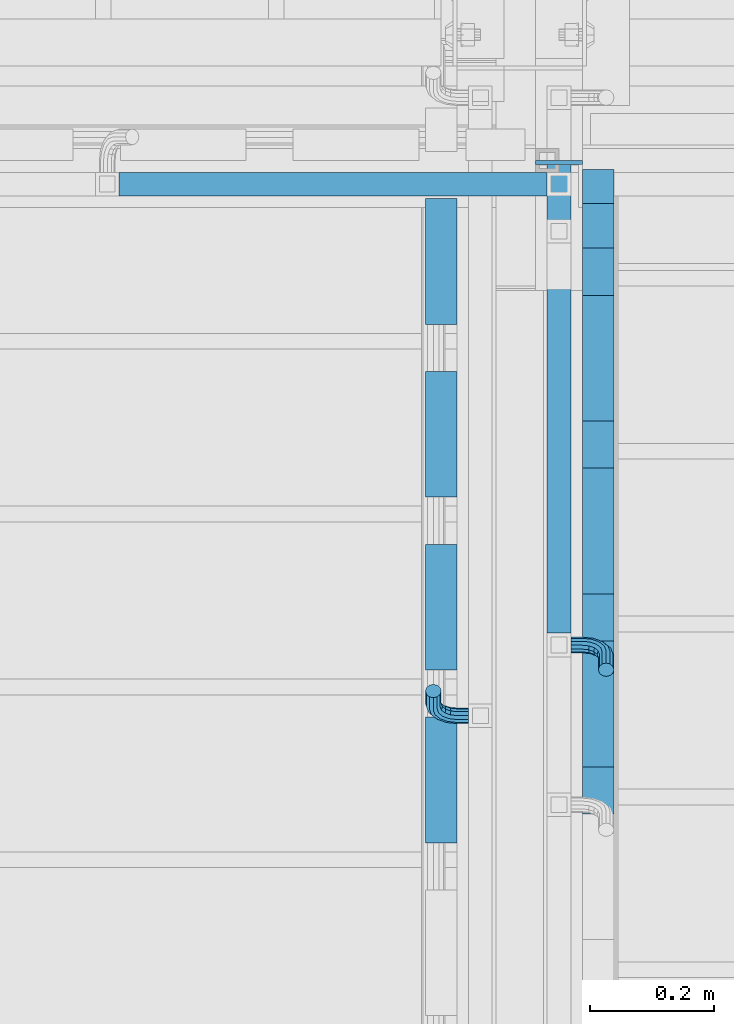
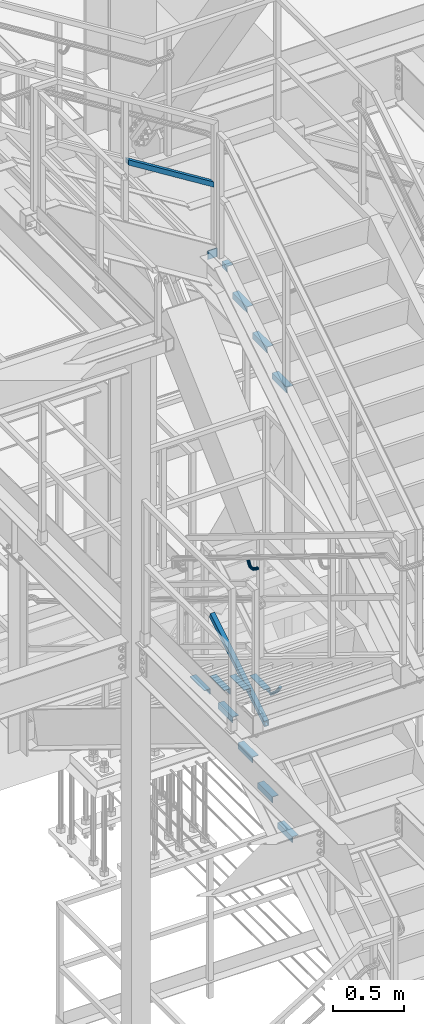
# One storey, part 2087 of 3843: 15 beams, 2 members, 6 elements without a shape of their own.
"""IFC2X3 building model written with IfcOpenShell, lengths in millimetres."""

from ifc_helpers import new_model, si_unit, frame, origin_with_axes, place, context, subcontext, project, spatial, faceted_brep, material, type_object, element, aggregate, save


model = new_model("IFC2X3")

# Units and contexts
model_context = context("Model", 3, precision=1e-05, world=origin_with_axes())
body_context = subcontext(model_context, "Body", "Model", "MODEL_VIEW")
ifc_project = project(units=[si_unit("LENGTHUNIT", "METRE", prefix="MILLI"), si_unit("AREAUNIT", "SQUARE_METRE"), si_unit("VOLUMEUNIT", "CUBIC_METRE"), si_unit("MASSUNIT", "GRAM", prefix="KILO"), si_unit("TIMEUNIT", "SECOND"), si_unit("PLANEANGLEUNIT", "RADIAN"), si_unit("SOLIDANGLEUNIT", "STERADIAN"), si_unit("THERMODYNAMICTEMPERATUREUNIT", "DEGREE_CELSIUS"), si_unit("LUMINOUSINTENSITYUNIT", "LUMEN")], contexts=[model_context])

# Site, building, storey
site_placement = place(None, origin_with_axes())
site = spatial("IfcSite", under=ifc_project, at=site_placement, CompositionType="ELEMENT")
building_placement = place(site_placement, origin_with_axes())
building = spatial("IfcBuilding", under=site, at=building_placement, Name="Undefined", CompositionType="ELEMENT")
storey_placement = place(building_placement, origin_with_axes())
storey = spatial("IfcBuildingStorey", under=building, at=storey_placement, Name="Undefined", CompositionType="ELEMENT", Elevation=0.0)

# Assembly, member
assembly_1_placement = place(storey_placement, origin_with_axes())
assembly_1 = element("IfcElementAssembly", 1, at=assembly_1_placement, inside=storey, Name="RAIL", AssemblyPlace="NOTDEFINED", PredefinedType="RIGID_FRAME")
ifc_material_1 = material()
member_type = type_object("IfcMemberType", Name="HSS1-1/2X1-1/2X1/4", PredefinedType="NOTDEFINED")
member_1_placement = place(assembly_1_placement, frame((54444.9000000001, 21717.0000000151, 37299.2842403544), z_axis=(0.529536736899108, 0.0, 0.848287005838381), x_axis=(-0.848287005838377, 0.0, 0.529536736899114)))
member_1 = element("IfcMember", 2, at=member_1_placement, type_object=member_type, material=ifc_material_1, Name="RAIL", ObjectType="HSS1-1/2X1-1/2X1/4", context=body_context, shape_type="Brep", body=[
    faceted_brep([(14.5291436874832, 12.6999993300014, -12.6999993299687), (14.5291436874832, -12.6999993300014, -12.6999993299687), (830.467611756969, -12.6999993300014, -12.6999993309219), (830.467611756969, 12.6999993300014, -12.6999993309219), (30.3849004243275, -12.6999993300014, 12.6999993299178), (846.323368493817, -12.6999993300014, 12.6999993289719), (30.3849004243275, 12.6999993300014, 12.6999993299178), (846.323368493817, 12.6999993300014, 12.6999993289719), (10.5652043534537, 19.0499992350015, -19.0499992349432), (34.3488397583606, 19.0499992350015, 19.0499992348923), (850.28730782785, 19.0499992350015, 19.0499992339464), (826.503672422943, 19.0499992350015, -19.0499992358891), (34.3488397583606, -19.0499999999956, 19.0499992348923), (850.28730782785, -19.0499992350015, 19.0499992339464), (10.5652043534537, -19.0499992350015, -19.0499992349432), (826.503672422943, -19.0499992350015, -19.0499992358891)], [[[0, 1, 2, 3]], [[1, 4, 5, 2]], [[4, 6, 7, 5]], [[6, 0, 3, 7]], [[8, 9, 10, 11]], [[9, 12, 13, 10]], [[12, 14, 15, 13]], [[14, 8, 11, 15]], [[13, 15, 11, 10], [5, 7, 3, 2]], [[12, 9, 8, 14], [4, 1, 0, 6]]]),
])
aggregate(assembly_1, [member_1])

assembly_2_placement = place(storey_placement, origin_with_axes())
assembly_2 = element("IfcElementAssembly", 3, at=assembly_2_placement, inside=storey, Name="RAIL", AssemblyPlace="NOTDEFINED", PredefinedType="RIGID_FRAME")
member_2_placement = place(assembly_2_placement, frame((54444.8999999944, 20971.9333333393, 33110.5282038454), z_axis=(0.0, -0.524097425050603, 0.851658317082225), x_axis=(0.0, 0.851658317082228, 0.524097425050598)))
member_2 = element("IfcMember", 4, at=member_2_placement, type_object=member_type, material=ifc_material_1, Name="RAIL", ObjectType="HSS1-1/2X1-1/2X1/4", context=body_context, shape_type="Brep", body=[
    faceted_brep([(14.5527402998268, 12.6999993300014, -12.6999993299833), (14.5527402998268, -12.6999993300014, -12.6999993299833), (915.983851926532, -12.6999993299978, -12.6999993318641), (915.983851926532, 12.6999993299978, -12.6999993318641), (30.1835087105574, -12.6999993300014, 12.6999993299978), (923.173123174471, -12.6999993299978, 12.6999993282116), (30.1835087105574, 12.6999993300014, 12.6999993299978), (923.173123174471, 12.6999993299978, 12.6999993282116), (10.6450480494532, 19.0499992350015, -19.0499992349796), (34.091200960931, 19.0499992350015, 19.0499992349942), (924.970441054393, 19.0499992350015, 19.049999233237), (914.18653404661, 19.0499992350015, -19.0499992368896), (34.091200960931, -19.0499992350015, 19.0499992349942), (924.970441054393, -19.0499992350015, 19.049999233237), (10.6450480494532, -19.0499992350015, -19.0499992349796), (914.18653404661, -19.0499992350015, -19.0499992368896)], [[[0, 1, 2, 3]], [[1, 4, 5, 2]], [[4, 6, 7, 5]], [[6, 0, 3, 7]], [[8, 9, 10, 11]], [[9, 12, 13, 10]], [[12, 14, 15, 13]], [[14, 8, 11, 15]], [[13, 15, 11, 10], [5, 7, 3, 2]], [[14, 12, 9, 8], [6, 4, 1, 0]]]),
])

# Assembly, beams
assembly_3_placement = place(storey_placement, origin_with_axes())
assembly_3 = element("IfcElementAssembly", 5, at=assembly_3_placement, inside=storey, Name="STAIR", AssemblyPlace="NOTDEFINED", PredefinedType="RIGID_FRAME")
ifc_material_2 = material(Name="STEEL/A36")
beam_type_1 = type_object("IfcBeamType", PredefinedType="NOTDEFINED")
beam_1_placement = place(assembly_3_placement, frame((54483.0000001399, 21751.9250000865, 36681.8333313492), z_axis=(0.0, 0.0, 1.0), x_axis=(-1.0, 0.0, 0.0)))
beam_1 = element("IfcBeam", 6, at=beam_1_placement, type_object=beam_type_1, material=ifc_material_2, Name="PLATE", context=body_context, shape_type="Brep", body=[
    faceted_brep([(0.0, 3.17500000000291, -38.0999999999985), (0.0, 3.17500000000291, 38.0999999999985), (76.2000000001353, 3.17499999999927, 38.0999999997584), (76.1999999998952, 3.17499999999927, -38.1000000002459), (0.0, -3.17500000000291, 38.0999999999985), (76.2000000001353, -3.17499999999927, 38.0999999997584), (0.0, -3.17500000000291, -38.0999999999985), (76.1999999998952, -3.17499999999927, -38.1000000002459)], [[[0, 1, 2, 3]], [[1, 4, 5, 2]], [[4, 6, 7, 5]], [[6, 0, 3, 7]], [[5, 7, 3, 2]], [[6, 4, 1, 0]]]),
])
beam_type_2 = type_object("IfcBeamType", Name="L2X2X3/16", PredefinedType="NOTDEFINED")
beam_2_placement = place(assembly_3_placement, frame((54508.3999999688, 21613.3065499512, 36618.3333312903), z_axis=(1.0, 0.0, 0.0), x_axis=(0.0, 1.0, 0.0)))
beam_2 = element("IfcBeam", 7, at=beam_2_placement, type_object=beam_type_2, material=ifc_material_2, Name="ANGLE", ObjectType="L2X2X3/16", context=body_context, shape_type="Brep", body=[
    faceted_brep([(0.0, 25.4000000000015, -25.4000000000015), (0.0, 25.4000000000015, 25.4000000000015), (71.9434500455318, 25.4000000000015, 25.4000000000015), (71.9434500455318, 25.4000000000015, -25.4000000000015), (0.0, 20.6375000000007, 25.4000000000015), (71.9434500455318, 20.6374999999971, 25.4000000000015), (0.0, 20.6375000000007, -20.6375000000007), (71.9434500455318, 20.6374999999971, -20.6374999999971), (0.0, -25.4000000000015, -20.6375000000007), (71.9434500455318, -25.4000000000015, -20.6374999999971), (0.0, -25.4000000000015, -25.4000000000015), (71.9434500455318, -25.4000000000015, -25.4000000000015)], [[[0, 1, 2, 3]], [[1, 4, 5, 2]], [[4, 6, 7, 5]], [[6, 8, 9, 7]], [[8, 10, 11, 9]], [[10, 0, 3, 11]], [[5, 7, 9, 11, 3, 2]], [[10, 8, 6, 4, 1, 0]]]),
])

# Assembly, beam
assembly_4_placement = place(storey_placement, origin_with_axes())
assembly_4 = element("IfcElementAssembly", 8, at=assembly_4_placement, inside=storey, Name="STAIR", AssemblyPlace="NOTDEFINED", PredefinedType="RIGID_FRAME")
beam_3_placement = place(assembly_4_placement, frame((54254.4000000118, 21693.5859969458, 33151.6403827575), z_axis=(-1.0, 0.0, 0.0), x_axis=(0.0, -1.0, 0.0)))
beam_3 = element("IfcBeam", 9, at=beam_3_placement, type_object=beam_type_2, material=ifc_material_2, Name="ANGLE", ObjectType="L2X2X3/16", context=body_context, shape_type="Brep", body=[
    faceted_brep([(0.0, 25.4000000000015, -25.4000000000015), (0.0, 25.4000000000015, 25.4000000000015), (203.199999999997, 25.4000000000015, 25.4000000000015), (203.199999999997, 25.4000000000015, -25.4000000000015), (0.0, 20.6375000000007, 25.4000000000015), (203.199999999997, 20.6375000000007, 25.4000000000015), (0.0, 20.6375000000007, -20.6375000000007), (203.199999999997, 20.6375000000007, -20.6375000000007), (0.0, -25.4000000000015, -20.6375000000007), (203.199999999997, -25.4000000000015, -20.6375000000007), (0.0, -25.4000000000015, -25.4000000000015), (203.199999999997, -25.4000000000015, -25.4000000000015)], [[[0, 1, 2, 3]], [[1, 4, 5, 2]], [[4, 6, 7, 5]], [[6, 8, 9, 7]], [[8, 10, 11, 9]], [[10, 0, 3, 11]], [[5, 7, 9, 11, 3, 2]], [[10, 8, 6, 4, 1, 0]]]),
])

# Beam
beam_4_placement = place(assembly_3_placement, frame((54508.3999999688, 21333.9065499542, 36440.7449978648), z_axis=(1.0, 0.0, 0.0), x_axis=(0.0, 1.0, 0.0)))
beam_4 = element("IfcBeam", 10, at=beam_4_placement, type_object=beam_type_2, material=ifc_material_2, Name="ANGLE", ObjectType="L2X2X3/16", context=body_context, shape_type="Brep", body=[
    faceted_brep([(0.0, 25.4000000000015, -25.4000000000015), (0.0, 25.4000000000015, 25.4000000000015), (203.199999999997, 25.4000000000015, 25.4000000000015), (203.199999999997, 25.4000000000015, -25.4000000000015), (0.0, 20.6375000000007, 25.4000000000015), (203.199999999997, 20.6375000000007, 25.4000000000015), (0.0, 20.6375000000007, -20.6375000000007), (203.199999999997, 20.6375000000007, -20.6375000000007), (0.0, -25.4000000000015, -20.6375000000007), (203.199999999997, -25.4000000000015, -20.6375000000007), (0.0, -25.4000000000015, -25.4000000000015), (203.199999999997, -25.4000000000015, -25.4000000000015)], [[[0, 1, 2, 3]], [[1, 4, 5, 2]], [[4, 6, 7, 5]], [[6, 8, 9, 7]], [[8, 10, 11, 9]], [[10, 0, 3, 11]], [[5, 7, 9, 11, 3, 2]], [[10, 8, 6, 4, 1, 0]]]),
])

beam_5_placement = place(assembly_3_placement, frame((54508.3999999688, 21054.5065499538, 36266.3316644321), z_axis=(1.0, 0.0, 0.0), x_axis=(0.0, 1.0, 0.0)))
beam_5 = element("IfcBeam", 11, at=beam_5_placement, type_object=beam_type_2, material=ifc_material_2, Name="ANGLE", ObjectType="L2X2X3/16", context=body_context, shape_type="Brep", body=[
    faceted_brep([(0.0, 25.4000000000015, -25.4000000000015), (0.0, 25.4000000000015, 25.4000000000015), (203.199999999997, 25.4000000000015, 25.4000000000015), (203.199999999997, 25.4000000000015, -25.4000000000015), (0.0, 20.6375000000007, 25.4000000000015), (203.199999999997, 20.6375000000007, 25.4000000000015), (0.0, 20.6375000000007, -20.6375000000007), (203.199999999997, 20.6375000000007, -20.6375000000007), (0.0, -25.4000000000015, -20.6375000000007), (203.199999999997, -25.4000000000015, -20.6375000000007), (0.0, -25.4000000000015, -25.4000000000015), (203.199999999997, -25.4000000000015, -25.4000000000015)], [[[0, 1, 2, 3]], [[1, 4, 5, 2]], [[4, 6, 7, 5]], [[6, 8, 9, 7]], [[8, 10, 11, 9]], [[10, 0, 3, 11]], [[5, 7, 9, 11, 3, 2]], [[10, 8, 6, 4, 1, 0]]]),
])

beam_6_placement = place(assembly_3_placement, frame((54508.3999999688, 20775.1065499534, 36091.9183309994), z_axis=(1.0, 0.0, 0.0), x_axis=(0.0, 1.0, 0.0)))
beam_6 = element("IfcBeam", 12, at=beam_6_placement, type_object=beam_type_2, material=ifc_material_2, Name="ANGLE", ObjectType="L2X2X3/16", context=body_context, shape_type="Brep", body=[
    faceted_brep([(0.0, 25.4000000000015, -25.4000000000015), (0.0, 25.4000000000015, 25.4000000000015), (203.199999999997, 25.4000000000015, 25.4000000000015), (203.199999999997, 25.4000000000015, -25.4000000000015), (0.0, 20.6375000000007, 25.4000000000015), (203.199999999997, 20.6375000000007, 25.4000000000015), (0.0, 20.6375000000007, -20.6375000000007), (203.199999999997, 20.6375000000007, -20.6375000000007), (0.0, -25.4000000000015, -20.6375000000007), (203.199999999997, -25.4000000000015, -20.6375000000007), (0.0, -25.4000000000015, -25.4000000000015), (203.199999999997, -25.4000000000015, -25.4000000000015)], [[[0, 1, 2, 3]], [[1, 4, 5, 2]], [[4, 6, 7, 5]], [[6, 8, 9, 7]], [[8, 10, 11, 9]], [[10, 0, 3, 11]], [[5, 7, 9, 11, 3, 2]], [[10, 8, 6, 4, 1, 0]]]),
])

aggregate(assembly_3, [beam_2, beam_1, beam_4, beam_5, beam_6])

beam_7_placement = place(assembly_4_placement, frame((54254.4000000214, 20855.3859969448, 33667.4557669617), z_axis=(-1.0, 0.0, 0.0), x_axis=(0.0, -1.0, 0.0)))
beam_7 = element("IfcBeam", 13, at=beam_7_placement, type_object=beam_type_2, material=ifc_material_2, Name="ANGLE", ObjectType="L2X2X3/16", context=body_context, shape_type="Brep", body=[
    faceted_brep([(0.0, 25.4000000000015, -25.4000000000015), (0.0, 25.4000000000015, 25.4000000000015), (203.199999999997, 25.4000000000015, 25.4000000000015), (203.199999999997, 25.4000000000015, -25.4000000000015), (0.0, 20.6375000000007, 25.4000000000015), (203.199999999997, 20.6375000000007, 25.4000000000015), (0.0, 20.6375000000007, -20.6375000000007), (203.199999999997, 20.6375000000007, -20.6375000000007), (0.0, -25.4000000000015, -20.6375000000007), (203.199999999997, -25.4000000000015, -20.6375000000007), (0.0, -25.4000000000015, -25.4000000000015), (203.199999999997, -25.4000000000015, -25.4000000000015)], [[[0, 1, 2, 3]], [[1, 4, 5, 2]], [[4, 6, 7, 5]], [[6, 8, 9, 7]], [[8, 10, 11, 9]], [[10, 0, 3, 11]], [[5, 7, 9, 11, 3, 2]], [[10, 8, 6, 4, 1, 0]]]),
])

beam_8_placement = place(assembly_4_placement, frame((54254.4000000189, 21134.7859969477, 33495.5173055467), z_axis=(-1.0, 0.0, 0.0), x_axis=(0.0, -1.0, 0.0)))
beam_8 = element("IfcBeam", 14, at=beam_8_placement, type_object=beam_type_2, material=ifc_material_2, Name="ANGLE", ObjectType="L2X2X3/16", context=body_context, shape_type="Brep", body=[
    faceted_brep([(0.0, 25.4000000000015, -25.4000000000015), (0.0, 25.4000000000015, 25.4000000000015), (203.199999999997, 25.4000000000015, 25.4000000000015), (203.199999999997, 25.4000000000015, -25.4000000000015), (0.0, 20.6375000000007, 25.4000000000015), (203.199999999997, 20.6375000000007, 25.4000000000015), (0.0, 20.6375000000007, -20.6375000000007), (203.199999999997, 20.6375000000007, -20.6375000000007), (0.0, -25.4000000000015, -20.6375000000007), (203.199999999997, -25.4000000000015, -20.6375000000007), (0.0, -25.4000000000015, -25.4000000000015), (203.199999999997, -25.4000000000015, -25.4000000000015)], [[[0, 1, 2, 3]], [[1, 4, 5, 2]], [[4, 6, 7, 5]], [[6, 8, 9, 7]], [[8, 10, 11, 9]], [[10, 0, 3, 11]], [[5, 7, 9, 11, 3, 2]], [[10, 8, 6, 4, 1, 0]]]),
])

beam_9_placement = place(assembly_4_placement, frame((54254.4000000164, 21414.1859969506, 33323.5788441317), z_axis=(-1.0, 0.0, 0.0), x_axis=(0.0, -1.0, 0.0)))
beam_9 = element("IfcBeam", 15, at=beam_9_placement, type_object=beam_type_2, material=ifc_material_2, Name="ANGLE", ObjectType="L2X2X3/16", context=body_context, shape_type="Brep", body=[
    faceted_brep([(0.0, 25.4000000000015, -25.4000000000015), (0.0, 25.4000000000015, 25.4000000000015), (203.199999999997, 25.4000000000015, 25.4000000000015), (203.199999999997, 25.4000000000015, -25.4000000000015), (0.0, 20.6375000000007, 25.4000000000015), (203.199999999997, 20.6375000000007, 25.4000000000015), (0.0, 20.6375000000007, -20.6375000000007), (203.199999999997, 20.6375000000007, -20.6375000000007), (0.0, -25.4000000000015, -20.6375000000007), (203.199999999997, -25.4000000000015, -20.6375000000007), (0.0, -25.4000000000015, -25.4000000000015), (203.199999999997, -25.4000000000015, -25.4000000000015)], [[[0, 1, 2, 3]], [[1, 4, 5, 2]], [[4, 6, 7, 5]], [[6, 8, 9, 7]], [[8, 10, 11, 9]], [[10, 0, 3, 11]], [[5, 7, 9, 11, 3, 2]], [[10, 8, 6, 4, 1, 0]]]),
])

aggregate(assembly_4, [beam_3, beam_7, beam_8, beam_9])

# Assembly, beams
assembly_5_placement = place(storey_placement, origin_with_axes())
assembly_5 = element("IfcElementAssembly", 16, at=assembly_5_placement, inside=storey, Name="STAIR", AssemblyPlace="NOTDEFINED", PredefinedType="RIGID_FRAME")
beam_10_placement = place(assembly_5_placement, frame((54508.3999999749, 21537.2140030453, 32807.7634598906), z_axis=(1.0, 0.0, 0.0), x_axis=(0.0, 1.0, 0.0)))
beam_10 = element("IfcBeam", 17, at=beam_10_placement, type_object=beam_type_2, material=ifc_material_2, Name="ANGLE", ObjectType="L2X2X3/16", context=body_context, shape_type="Brep", body=[
    faceted_brep([(0.0, 25.4000000000015, -25.4000000000015), (0.0, 25.4000000000015, 25.4000000000015), (203.199999999997, 25.4000000000015, 25.4000000000015), (203.199999999997, 25.4000000000015, -25.4000000000015), (0.0, 20.6375000000007, 25.4000000000015), (203.199999999997, 20.6375000000007, 25.4000000000015), (0.0, 20.6375000000007, -20.6375000000007), (203.199999999997, 20.6375000000007, -20.6375000000007), (0.0, -25.4000000000015, -20.6375000000007), (203.199999999997, -25.4000000000015, -20.6375000000007), (0.0, -25.4000000000015, -25.4000000000015), (203.199999999997, -25.4000000000015, -25.4000000000015)], [[[0, 1, 2, 3]], [[1, 4, 5, 2]], [[4, 6, 7, 5]], [[6, 8, 9, 7]], [[8, 10, 11, 9]], [[10, 0, 3, 11]], [[5, 7, 9, 11, 3, 2]], [[10, 8, 6, 4, 1, 0]]]),
])
beam_11_placement = place(assembly_5_placement, frame((54508.3999999749, 21257.8140030462, 32635.8249984695), z_axis=(1.0, 0.0, 0.0), x_axis=(0.0, 1.0, 0.0)))
beam_11 = element("IfcBeam", 18, at=beam_11_placement, type_object=beam_type_2, material=ifc_material_2, Name="ANGLE", ObjectType="L2X2X3/16", context=body_context, shape_type="Brep", body=[
    faceted_brep([(0.0, 25.4000000000015, -25.4000000000015), (0.0, 25.4000000000015, 25.4000000000015), (203.199999999997, 25.4000000000015, 25.4000000000015), (203.199999999997, 25.4000000000015, -25.4000000000015), (0.0, 20.6375000000007, 25.4000000000015), (203.199999999997, 20.6375000000007, 25.4000000000015), (0.0, 20.6375000000007, -20.6375000000007), (203.199999999997, 20.6375000000007, -20.6375000000007), (0.0, -25.4000000000015, -20.6375000000007), (203.199999999997, -25.4000000000015, -20.6375000000007), (0.0, -25.4000000000015, -25.4000000000015), (203.199999999997, -25.4000000000015, -25.4000000000015)], [[[0, 1, 2, 3]], [[1, 4, 5, 2]], [[4, 6, 7, 5]], [[6, 8, 9, 7]], [[8, 10, 11, 9]], [[10, 0, 3, 11]], [[5, 7, 9, 11, 3, 2]], [[10, 8, 6, 4, 1, 0]]]),
])
beam_12_placement = place(assembly_5_placement, frame((54508.3999999749, 20978.4140030463, 32463.8865370502), z_axis=(1.0, 0.0, 0.0), x_axis=(0.0, 1.0, 0.0)))
beam_12 = element("IfcBeam", 19, at=beam_12_placement, type_object=beam_type_2, material=ifc_material_2, Name="ANGLE", ObjectType="L2X2X3/16", context=body_context, shape_type="Brep", body=[
    faceted_brep([(0.0, 25.4000000000015, -25.4000000000015), (0.0, 25.4000000000015, 25.4000000000015), (203.199999999997, 25.4000000000015, 25.4000000000015), (203.199999999997, 25.4000000000015, -25.4000000000015), (0.0, 20.6375000000007, 25.4000000000015), (203.199999999997, 20.6375000000007, 25.4000000000015), (0.0, 20.6375000000007, -20.6375000000007), (203.199999999997, 20.6375000000007, -20.6375000000007), (0.0, -25.4000000000015, -20.6375000000007), (203.199999999997, -25.4000000000015, -20.6375000000007), (0.0, -25.4000000000015, -25.4000000000015), (203.199999999997, -25.4000000000015, -25.4000000000015)], [[[0, 1, 2, 3]], [[1, 4, 5, 2]], [[4, 6, 7, 5]], [[6, 8, 9, 7]], [[8, 10, 11, 9]], [[10, 0, 3, 11]], [[5, 7, 9, 11, 3, 2]], [[10, 8, 6, 4, 1, 0]]]),
])
beam_13_placement = place(assembly_5_placement, frame((54508.3999999749, 20699.0140030456, 32291.9480756302), z_axis=(1.0, 0.0, 0.0), x_axis=(0.0, 1.0, 0.0)))
beam_13 = element("IfcBeam", 20, at=beam_13_placement, type_object=beam_type_2, material=ifc_material_2, Name="ANGLE", ObjectType="L2X2X3/16", context=body_context, shape_type="Brep", body=[
    faceted_brep([(0.0, 25.4000000000015, -25.4000000000015), (0.0, 25.4000000000015, 25.4000000000015), (203.199999999997, 25.4000000000015, 25.4000000000015), (203.199999999997, 25.4000000000015, -25.4000000000015), (0.0, 20.6375000000007, 25.4000000000015), (203.199999999997, 20.6375000000007, 25.4000000000015), (0.0, 20.6375000000007, -20.6375000000007), (203.199999999997, 20.6375000000007, -20.6375000000007), (0.0, -25.4000000000015, -20.6375000000007), (203.199999999997, -25.4000000000015, -20.6375000000007), (0.0, -25.4000000000015, -25.4000000000015), (203.199999999997, -25.4000000000015, -25.4000000000015)], [[[0, 1, 2, 3]], [[1, 4, 5, 2]], [[4, 6, 7, 5]], [[6, 8, 9, 7]], [[8, 10, 11, 9]], [[10, 0, 3, 11]], [[5, 7, 9, 11, 3, 2]], [[10, 8, 6, 4, 1, 0]]]),
])
aggregate(assembly_5, [beam_10, beam_11, beam_12, beam_13])

# Assembly, beam
assembly_6_placement = place(storey_placement, origin_with_axes())
assembly_6 = element("IfcElementAssembly", 21, at=assembly_6_placement, inside=storey, Name="RAIL", AssemblyPlace="NOTDEFINED", PredefinedType="RIGID_FRAME")
beam_type_3 = type_object("IfcBeamType", PredefinedType="NOTDEFINED")
beam_14_placement = place(assembly_6_placement, frame((54298.85, 20857.6333333263, 34585.8619338513), z_axis=(0.0, 0.851658317082228, -0.524097425050598), x_axis=(-1.0, 0.0, 0.0)))
beam_14 = element("IfcBeam", 22, at=beam_14_placement, type_object=beam_type_3, material=ifc_material_2, Name="BRACKET ARM", context=body_context, shape_type="Brep", body=[
    faceted_brep([(0.0, -12.6999999999971, 0.0), (0.0, -10.9985226280696, -6.34999999999854), (19.0500015258731, -10.9985226280623, -6.34999999999854), (19.0500015258731, -12.6999999999971, -6.33008312433958e-10), (0.0, -6.35000000000582, -10.9985226280623), (19.0500015258731, -6.34999999999854, -10.9985226280623), (0.0, 0.0, -12.6999999999971), (19.0500015258731, 0.0, -12.6999999999971), (0.0, 6.35000000000582, -10.9985226280623), (19.0500015258731, 6.34999999999854, -10.9985226280623), (0.0, 10.9985226280696, -6.34999999999854), (19.0500015258731, 10.9985226280623, -6.34999999999854), (0.0, 12.6999999999971, 0.0), (19.0500015258731, 12.6999999999971, 0.0), (0.0, 10.9985226280696, 6.34999999999854), (19.0500015258731, 10.9985226280623, 6.34999999999854), (0.0, 6.35000000000582, 10.9985226280623), (19.0500015258731, 6.34999999999854, 10.9985226280623), (0.0, 0.0, 12.6999999999971), (19.0500015258731, 0.0, 12.6999999999971), (0.0, -6.35000000000582, 10.9985226280623), (19.0500015258731, -6.34999999999854, 10.9985226280623), (0.0, -10.9985226280696, 6.34999999999854), (19.0500015258731, -10.9985226280623, 6.34999999999854), (38.4903193060891, -8.8330803677236, -3.34694050252438e-10), (37.8391921052389, -7.26112024908798, 6.34999999974389), (36.0602795104642, -2.96644533684594, 10.9985226280041), (33.6302397149266, 2.90018969451194, 12.7000000002226), (31.2001999194181, 8.76682472604443, 10.9985226285644), (29.4212873247307, 13.061499638774, 6.35000000070431), (28.7701601240115, 14.6334597580644, 7.78527464717627e-10), (29.4212873248762, 13.0614996394288, -6.34999999929278), (31.2001999196509, 8.76682472718676, -10.9985226275603), (33.6302397151885, 2.90018969582889, -12.6999999997788), (36.0602795106824, -2.96644533571089, -10.9985226281206), (37.8391921053699, -7.26112024843314, -6.35000000026048), (53.7678987435793, 3.38210125690239, -6.3499999994383), (54.9710249311902, 2.17897506880399, 5.0931703299284e-10), (50.4808968708676, 6.66910312997061, -10.9985226273784), (45.9907688103704, 11.1592311906061, -12.6999999991458), (41.5006407498004, 15.6493592510378, -10.9985226270364), (38.213638876914, 18.9363611235749, -6.34999999884167), (37.0105126890558, 20.1394873109457, 1.20053300634027e-09), (38.2136388766667, 18.9363611228473, 6.35000000115542), (41.5006407493784, 15.6493592497718, 10.9985226290883), (45.9907688098756, 11.1592311891436, 12.7000000008557), (50.4808968704456, 6.66910312870459, 10.9985226287463), (53.7678987433319, 3.38210125617479, 6.35000000055879), (64.4111202489148, 19.3108078951118, -6.34999999821594), (65.9830803677178, 18.6596806939051, 1.77533365786076e-09), (60.1164453365491, 21.0897204901557, -10.9985226262725), (54.2498103051475, 23.5197602857806, -12.6999999981927), (48.3831752736587, 25.9498000811873, -10.9985226262434), (44.0885003610601, 27.7287126756128, -6.34999999817228), (42.516540241937, 28.3798398759754, 1.83354131877422e-09), (44.08850036074, 27.7287126747688, 6.35000000183209), (48.3831752731057, 25.9498000797321, 10.9985226298813), (54.2498103045073, 23.5197602840999, 12.7000000018088), (60.1164453359961, 21.0897204886933, 10.9985226298522), (64.4111202485947, 19.3108078942678, 6.35000000178115), (68.1485226282239, 38.0999984746086, -6.3499999967753), (69.8499999999913, 38.0999984741211, 2.92493496090174e-09), (63.500000000291, 38.0999984749651, -10.9985226249628), (57.1500000003434, 38.0999984750961, -12.6999999970722), (50.8000000002939, 38.0999984749651, -10.998522625312), (46.1514773720992, 38.0999984746086, -6.34999999737192), (44.4499999999971, 38.0999984741211, 2.58296495303512e-09), (46.1514773717645, 38.0999984736336, 6.35000000262517), (50.7999999996973, 38.0999984732771, 10.9985226308127), (57.1499999996449, 38.0999984731461, 12.700000002922), (63.4999999996944, 38.0999984732771, 10.9985226311619), (68.1485226278892, 38.0999984736336, 6.35000000322179), (68.1485226280638, 76.2000000002372, -6.34999999414867), (69.8499999999913, 76.199999999757, 5.84986992180347e-09), (63.5, 76.200000000601, -10.9985226222125), (57.1499999999942, 76.2000000007247, -12.6999999941472), (50.7999999999884, 76.200000000601, -10.9985226222125), (46.1514773719246, 76.2000000002372, -6.34999999414867), (44.4499999999971, 76.199999999757, 5.84986992180347e-09), (46.1514773719246, 76.1999999992695, 6.35000000584841), (50.7999999999884, 76.1999999989057, 10.9985226339122), (57.1499999999942, 76.199999998782, 12.700000005847), (63.5, 76.1999999989057, 10.9985226339122), (68.1485226280638, 76.1999999992695, 6.35000000584841)], [[[0, 1, 2, 3]], [[1, 4, 5, 2]], [[4, 6, 7, 5]], [[6, 8, 9, 7]], [[8, 10, 11, 9]], [[10, 12, 13, 11]], [[12, 14, 15, 13]], [[14, 16, 17, 15]], [[16, 18, 19, 17]], [[18, 20, 21, 19]], [[20, 22, 23, 21]], [[22, 0, 3, 23]], [[22, 20, 18, 16, 14, 12, 10, 8, 6, 4, 1, 0]], [[23, 3, 24, 25]], [[21, 23, 25, 26]], [[19, 21, 26, 27]], [[17, 19, 27, 28]], [[15, 17, 28, 29]], [[13, 15, 29, 30]], [[11, 13, 30, 31]], [[9, 11, 31, 32]], [[7, 9, 32, 33]], [[5, 7, 33, 34]], [[2, 5, 34, 35]], [[3, 2, 35, 24]], [[35, 36, 37, 24]], [[34, 38, 36, 35]], [[33, 39, 38, 34]], [[32, 40, 39, 33]], [[31, 41, 40, 32]], [[30, 42, 41, 31]], [[29, 43, 42, 30]], [[28, 44, 43, 29]], [[27, 45, 44, 28]], [[26, 46, 45, 27]], [[25, 47, 46, 26]], [[24, 37, 47, 25]], [[36, 48, 49, 37]], [[38, 50, 48, 36]], [[39, 51, 50, 38]], [[40, 52, 51, 39]], [[41, 53, 52, 40]], [[42, 54, 53, 41]], [[43, 55, 54, 42]], [[44, 56, 55, 43]], [[45, 57, 56, 44]], [[46, 58, 57, 45]], [[47, 59, 58, 46]], [[37, 49, 59, 47]], [[48, 60, 61, 49]], [[50, 62, 60, 48]], [[51, 63, 62, 50]], [[52, 64, 63, 51]], [[53, 65, 64, 52]], [[54, 66, 65, 53]], [[55, 67, 66, 54]], [[56, 68, 67, 55]], [[57, 69, 68, 56]], [[58, 70, 69, 57]], [[59, 71, 70, 58]], [[49, 61, 71, 59]], [[61, 60, 72, 73]], [[60, 62, 74, 72]], [[62, 63, 75, 74]], [[63, 64, 76, 75]], [[64, 65, 77, 76]], [[65, 66, 78, 77]], [[66, 67, 79, 78]], [[67, 68, 80, 79]], [[68, 69, 81, 80]], [[69, 70, 82, 81]], [[70, 71, 83, 82]], [[71, 61, 73, 83]], [[74, 75, 76, 77, 78, 79, 80, 81, 82, 83, 73, 72]]]),
])
aggregate(assembly_6, [beam_14])

# Beam
beam_15_placement = place(assembly_2_placement, frame((54463.95, 20971.9333333355, 33379.6875746061), z_axis=(0.0, -0.851658317082228, -0.524097425050598), x_axis=(1.0, 0.0, 0.0)))
beam_15 = element("IfcBeam", 23, at=beam_15_placement, type_object=beam_type_3, material=ifc_material_2, Name="BRACKET ARM", context=body_context, shape_type="Brep", body=[
    faceted_brep([(0.0, -12.6999999999971, 0.0), (0.0, -10.9985226280696, -6.34999999999854), (19.0500015258731, -10.9985226280623, -6.34999999999854), (19.0500015258731, -12.6999999999971, -6.33008312433958e-10), (0.0, -6.35000000000582, -10.9985226280623), (19.0500015258731, -6.34999999999854, -10.9985226280623), (0.0, 0.0, -12.6999999999971), (19.0500015258731, 0.0, -12.6999999999971), (0.0, 6.35000000000582, -10.9985226280623), (19.0500015258731, 6.34999999999854, -10.9985226280623), (0.0, 10.9985226280696, -6.34999999999854), (19.0500015258731, 10.9985226280623, -6.34999999999854), (0.0, 12.6999999999971, 0.0), (19.0500015258731, 12.6999999999971, 0.0), (0.0, 10.9985226280696, 6.34999999999854), (19.0500015258731, 10.9985226280623, 6.34999999999854), (0.0, 6.35000000000582, 10.9985226280623), (19.0500015258731, 6.34999999999854, 10.9985226280623), (0.0, 0.0, 12.6999999999971), (19.0500015258731, 0.0, 12.6999999999971), (0.0, -6.35000000000582, 10.9985226280623), (19.0500015258731, -6.34999999999854, 10.9985226280623), (0.0, -10.9985226280696, 6.34999999999854), (19.0500015258731, -10.9985226280623, 6.34999999999854), (38.4903193060891, -8.8330803677236, -3.34694050252438e-10), (37.8391921052389, -7.26112024908798, 6.34999999974389), (36.0602795104642, -2.96644533684594, 10.9985226280041), (33.6302397149266, 2.90018969451194, 12.7000000002226), (31.2001999194181, 8.76682472604443, 10.9985226285644), (29.4212873247307, 13.061499638774, 6.35000000070431), (28.7701601240115, 14.6334597580644, 7.78527464717627e-10), (29.4212873248762, 13.0614996394288, -6.34999999929278), (31.2001999196509, 8.76682472718676, -10.9985226275603), (33.6302397151885, 2.90018969582889, -12.6999999997788), (36.0602795106824, -2.96644533571089, -10.9985226281206), (37.8391921053699, -7.26112024843314, -6.35000000026048), (53.7678987435793, 3.38210125690239, -6.3499999994383), (54.9710249311902, 2.17897506880399, 5.0931703299284e-10), (50.4808968708676, 6.66910312997061, -10.9985226273784), (45.9907688103704, 11.1592311906061, -12.6999999991458), (41.5006407498004, 15.6493592510378, -10.9985226270364), (38.213638876914, 18.9363611235749, -6.34999999884167), (37.0105126890558, 20.1394873109457, 1.20053300634027e-09), (38.2136388766667, 18.9363611228473, 6.35000000115542), (41.5006407493784, 15.6493592497718, 10.9985226290883), (45.9907688098756, 11.1592311891436, 12.7000000008557), (50.4808968704456, 6.66910312870459, 10.9985226287463), (53.7678987433319, 3.38210125617479, 6.35000000055879), (64.4111202489148, 19.3108078951118, -6.34999999821594), (65.9830803677178, 18.6596806939051, 1.77533365786076e-09), (60.1164453365491, 21.0897204901557, -10.9985226262725), (54.2498103051475, 23.5197602857806, -12.6999999981927), (48.3831752736587, 25.9498000811873, -10.9985226262434), (44.0885003610601, 27.7287126756128, -6.34999999817228), (42.516540241937, 28.3798398759754, 1.83354131877422e-09), (44.08850036074, 27.7287126747688, 6.35000000183209), (48.3831752731057, 25.9498000797321, 10.9985226298813), (54.2498103045073, 23.5197602840999, 12.7000000018088), (60.1164453359961, 21.0897204886933, 10.9985226298522), (64.4111202485947, 19.3108078942678, 6.35000000178115), (68.1485226282239, 38.0999984746086, -6.3499999967753), (69.8499999999913, 38.0999984741211, 2.92493496090174e-09), (63.500000000291, 38.0999984749651, -10.9985226249628), (57.1500000003434, 38.0999984750961, -12.6999999970722), (50.8000000002939, 38.0999984749651, -10.998522625312), (46.1514773720992, 38.0999984746086, -6.34999999737192), (44.4499999999971, 38.0999984741211, 2.58296495303512e-09), (46.1514773717645, 38.0999984736336, 6.35000000262517), (50.7999999996973, 38.0999984732771, 10.9985226308127), (57.1499999996449, 38.0999984731461, 12.700000002922), (63.4999999996944, 38.0999984732771, 10.9985226311619), (68.1485226278892, 38.0999984736336, 6.35000000322179), (68.1485226280638, 76.2000000002372, -6.34999999414867), (69.8499999999913, 76.199999999757, 5.84986992180347e-09), (63.5, 76.200000000601, -10.9985226222125), (57.1499999999942, 76.2000000007247, -12.6999999941472), (50.7999999999884, 76.200000000601, -10.9985226222125), (46.1514773719246, 76.2000000002372, -6.34999999414867), (44.4499999999971, 76.199999999757, 5.84986992180347e-09), (46.1514773719246, 76.1999999992695, 6.35000000584841), (50.7999999999884, 76.1999999989057, 10.9985226339122), (57.1499999999942, 76.199999998782, 12.700000005847), (63.5, 76.1999999989057, 10.9985226339122), (68.1485226280638, 76.1999999992695, 6.35000000584841)], [[[0, 1, 2, 3]], [[1, 4, 5, 2]], [[4, 6, 7, 5]], [[6, 8, 9, 7]], [[8, 10, 11, 9]], [[10, 12, 13, 11]], [[12, 14, 15, 13]], [[14, 16, 17, 15]], [[16, 18, 19, 17]], [[18, 20, 21, 19]], [[20, 22, 23, 21]], [[22, 0, 3, 23]], [[22, 20, 18, 16, 14, 12, 10, 8, 6, 4, 1, 0]], [[23, 3, 24, 25]], [[21, 23, 25, 26]], [[19, 21, 26, 27]], [[17, 19, 27, 28]], [[15, 17, 28, 29]], [[13, 15, 29, 30]], [[11, 13, 30, 31]], [[9, 11, 31, 32]], [[7, 9, 32, 33]], [[5, 7, 33, 34]], [[2, 5, 34, 35]], [[3, 2, 35, 24]], [[35, 36, 37, 24]], [[34, 38, 36, 35]], [[33, 39, 38, 34]], [[32, 40, 39, 33]], [[31, 41, 40, 32]], [[30, 42, 41, 31]], [[29, 43, 42, 30]], [[28, 44, 43, 29]], [[27, 45, 44, 28]], [[26, 46, 45, 27]], [[25, 47, 46, 26]], [[24, 37, 47, 25]], [[36, 48, 49, 37]], [[38, 50, 48, 36]], [[39, 51, 50, 38]], [[40, 52, 51, 39]], [[41, 53, 52, 40]], [[42, 54, 53, 41]], [[43, 55, 54, 42]], [[44, 56, 55, 43]], [[45, 57, 56, 44]], [[46, 58, 57, 45]], [[47, 59, 58, 46]], [[37, 49, 59, 47]], [[48, 60, 61, 49]], [[50, 62, 60, 48]], [[51, 63, 62, 50]], [[52, 64, 63, 51]], [[53, 65, 64, 52]], [[54, 66, 65, 53]], [[55, 67, 66, 54]], [[56, 68, 67, 55]], [[57, 69, 68, 56]], [[58, 70, 69, 57]], [[59, 71, 70, 58]], [[49, 61, 71, 59]], [[61, 60, 72, 73]], [[60, 62, 74, 72]], [[62, 63, 75, 74]], [[63, 64, 76, 75]], [[64, 65, 77, 76]], [[65, 66, 78, 77]], [[66, 67, 79, 78]], [[67, 68, 80, 79]], [[68, 69, 81, 80]], [[69, 70, 82, 81]], [[70, 71, 83, 82]], [[71, 61, 73, 83]], [[74, 75, 76, 77, 78, 79, 80, 81, 82, 83, 73, 72]]]),
])

aggregate(assembly_2, [beam_15, member_2])

save(model, "model.ifc")
